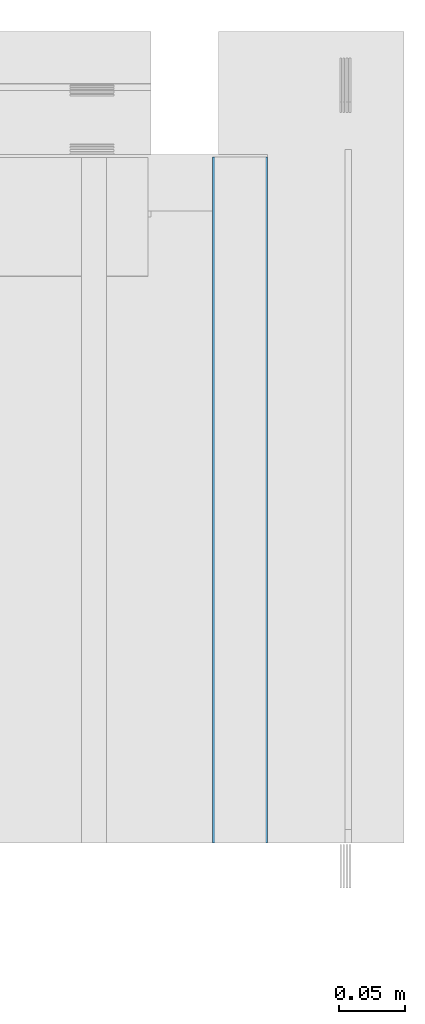
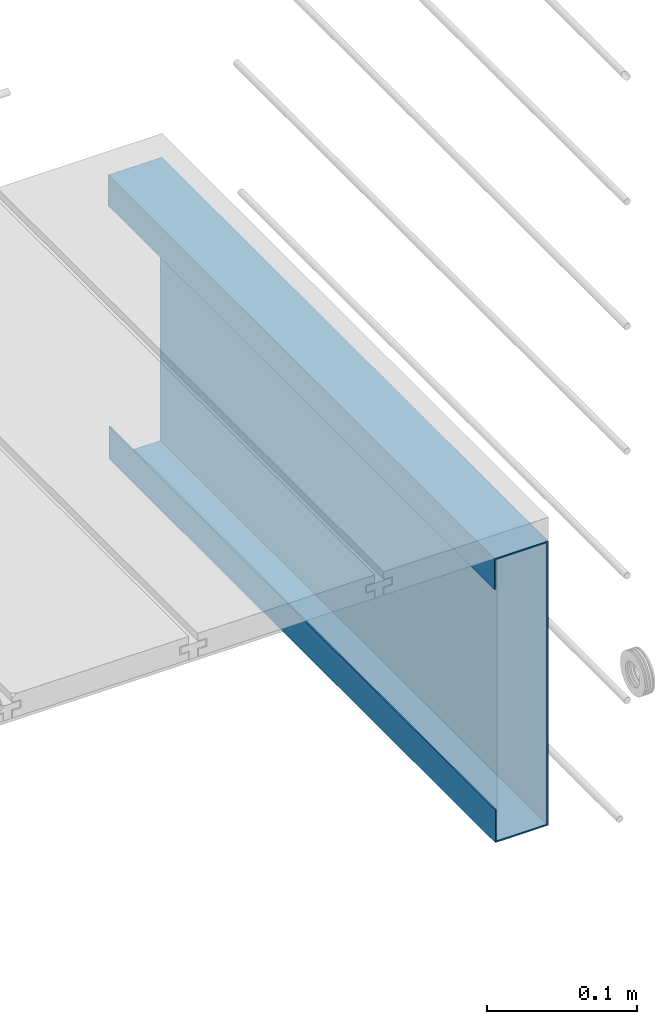
# One storey, part 25 of 33: 1 wall.
"""IFC4 building model written with IfcOpenShell, lengths in feet."""

from ifc_helpers import new_model, entity, si_unit, converted_unit, derived_unit, direction, frame, origin, place, context, subcontext, project, spatial, material, type_object, element, save


model = new_model("IFC4")

# Units and contexts
model_context = context("Model", 3, precision=0.0001, world=origin(), true_north=direction((6.12303176911189e-17, 1.0)))
body_context = subcontext(model_context, "Body", "Model", "MODEL_VIEW")
ifc_project = project(units=[converted_unit("LENGTHUNIT", "FOOT", entity("IfcRatioMeasure", 0.3048), si_unit("LENGTHUNIT", "METRE"), dimensions=[1, 0, 0, 0, 0, 0, 0]), converted_unit("AREAUNIT", "SQUARE FOOT", entity("IfcRatioMeasure", 0.09290304), si_unit("AREAUNIT", "SQUARE_METRE"), dimensions=[2, 0, 0, 0, 0, 0, 0]), converted_unit("VOLUMEUNIT", "CUBIC FOOT", entity("IfcRatioMeasure", 0.028316846592), si_unit("VOLUMEUNIT", "CUBIC_METRE"), dimensions=[3, 0, 0, 0, 0, 0, 0]), converted_unit("PLANEANGLEUNIT", "DEGREE", entity("IfcRatioMeasure", 0.0174532925199433), si_unit("PLANEANGLEUNIT", "RADIAN"), dimensions=[0, 0, 0, 0, 0, 0, 0]), si_unit("MASSUNIT", "GRAM", prefix="KILO"), derived_unit("MASSDENSITYUNIT", [(si_unit("MASSUNIT", "GRAM", prefix="KILO"), 1), (si_unit("LENGTHUNIT", "METRE"), -3)]), derived_unit("MOMENTOFINERTIAUNIT", [(si_unit("LENGTHUNIT", "METRE"), 4)]), si_unit("TIMEUNIT", "SECOND"), si_unit("FREQUENCYUNIT", "HERTZ"), si_unit("THERMODYNAMICTEMPERATUREUNIT", "DEGREE_CELSIUS"), derived_unit("THERMALTRANSMITTANCEUNIT", [(si_unit("MASSUNIT", "GRAM", prefix="KILO"), 1), (si_unit("THERMODYNAMICTEMPERATUREUNIT", "KELVIN"), -1), (si_unit("TIMEUNIT", "SECOND"), -3)]), derived_unit("VOLUMETRICFLOWRATEUNIT", [(si_unit("LENGTHUNIT", "METRE"), 3), (si_unit("TIMEUNIT", "SECOND"), -1)]), si_unit("ELECTRICCURRENTUNIT", "AMPERE"), si_unit("ELECTRICVOLTAGEUNIT", "VOLT"), si_unit("POWERUNIT", "WATT"), si_unit("FORCEUNIT", "NEWTON"), si_unit("ILLUMINANCEUNIT", "LUX"), si_unit("LUMINOUSFLUXUNIT", "LUMEN"), si_unit("LUMINOUSINTENSITYUNIT", "CANDELA"), derived_unit("USERDEFINED", [(si_unit("MASSUNIT", "GRAM", prefix="KILO"), -1), (si_unit("LENGTHUNIT", "METRE"), -2), (si_unit("TIMEUNIT", "SECOND"), 3), (si_unit("LUMINOUSFLUXUNIT", "LUMEN"), 1)]), derived_unit("LINEARVELOCITYUNIT", [(si_unit("LENGTHUNIT", "METRE"), 1), (si_unit("TIMEUNIT", "SECOND"), -1)]), si_unit("PRESSUREUNIT", "PASCAL"), derived_unit("USERDEFINED", [(si_unit("LENGTHUNIT", "METRE"), -2), (si_unit("MASSUNIT", "GRAM", prefix="KILO"), 1), (si_unit("TIMEUNIT", "SECOND"), -2)]), derived_unit("LINEARFORCEUNIT", [(si_unit("MASSUNIT", "GRAM", prefix="KILO"), 1), (si_unit("LENGTHUNIT", "METRE"), 1), (si_unit("TIMEUNIT", "SECOND"), -2), (si_unit("LENGTHUNIT", "METRE"), -1)]), derived_unit("PLANARFORCEUNIT", [(si_unit("MASSUNIT", "GRAM", prefix="KILO"), 1), (si_unit("LENGTHUNIT", "METRE"), 1), (si_unit("TIMEUNIT", "SECOND"), -2), (si_unit("LENGTHUNIT", "METRE"), -2)])], contexts=[model_context])

# Site, building, storey
site_placement = place(None, origin())
site = spatial("IfcSite", under=ifc_project, at=site_placement, CompositionType="ELEMENT")
building_placement = place(site_placement, origin())
building = spatial("IfcBuilding", under=site, at=building_placement, CompositionType="ELEMENT")
storey_placement = place(building_placement, frame((0.0, 0.0, 10.0)))
storey = spatial("IfcBuildingStorey", under=building, at=storey_placement, Name="2ND FLOOR", CompositionType="ELEMENT", Elevation=10.0000000000002)

# Wall
ifc_material = material(Name="METAL FLASHING - BLACK", Category="Materials")
wall_type = type_object("IfcWallType", Name="Generic Models 664:Generic Models 1", PredefinedType="NOTDEFINED", material=ifc_material)
wall_placement = place(storey_placement, frame((1494.16096048663, 3.04611392999272, -0.0780795093916034), z_axis=(0.0, 0.0, 1.0), x_axis=(0.0, 1.0, 0.0)))
cartesian_point_1 = entity("IfcCartesianPoint", [1.69301027184394, -0.13193225761438, 0.00359465998050723])
vertex_point_1 = entity("IfcVertexPoint", cartesian_point_1)
cartesian_point_2 = entity("IfcCartesianPoint", [1.69301027184395, -0.13193225761438, 0.756358646717025])
vertex_point_2 = entity("IfcVertexPoint", cartesian_point_2)
ifc_direction_1 = entity("IfcDirection", [0.0, 0.0, 1.0])
edge_curve_1 = entity("IfcEdgeCurve", vertex_point_1, vertex_point_2, entity("IfcTrimmedCurve", entity("IfcLine", cartesian_point_1, entity("IfcVector", ifc_direction_1, 1.0)), [cartesian_point_1], [cartesian_point_2], True, "CARTESIAN"), True)
cartesian_point_3 = entity("IfcCartesianPoint", [1.69301027184395, -0.0033333333333303, 0.756358646717025])
vertex_point_3 = entity("IfcVertexPoint", cartesian_point_3)
ifc_direction_2 = entity("IfcDirection", [0.0, 1.0, 0.0])
edge_curve_2 = entity("IfcEdgeCurve", vertex_point_2, vertex_point_3, entity("IfcTrimmedCurve", entity("IfcLine", cartesian_point_2, entity("IfcVector", ifc_direction_2, 1.0)), [cartesian_point_2], [cartesian_point_3], True, "CARTESIAN"), True)
cartesian_point_4 = entity("IfcCartesianPoint", [1.69301027184395, -0.0033333333333303, 0.67763552177091])
vertex_point_4 = entity("IfcVertexPoint", cartesian_point_4)
ifc_direction_3 = entity("IfcDirection", [0.0, 0.0, -1.0])
edge_curve_3 = entity("IfcEdgeCurve", vertex_point_3, vertex_point_4, entity("IfcTrimmedCurve", entity("IfcLine", cartesian_point_3, entity("IfcVector", ifc_direction_3, 1.0)), [cartesian_point_3], [cartesian_point_4], True, "CARTESIAN"), True)
cartesian_point_5 = entity("IfcCartesianPoint", [1.69301027184395, 0.0, 0.67763552177091])
vertex_point_5 = entity("IfcVertexPoint", cartesian_point_5)
edge_curve_4 = entity("IfcEdgeCurve", vertex_point_4, vertex_point_5, entity("IfcTrimmedCurve", entity("IfcLine", cartesian_point_4, entity("IfcVector", ifc_direction_2, 1.0)), [cartesian_point_4], [cartesian_point_5], True, "CARTESIAN"), True)
cartesian_point_6 = entity("IfcCartesianPoint", [1.69301027184395, 0.0, 0.759613855050359])
vertex_point_6 = entity("IfcVertexPoint", cartesian_point_6)
edge_curve_5 = entity("IfcEdgeCurve", vertex_point_5, vertex_point_6, entity("IfcTrimmedCurve", entity("IfcLine", cartesian_point_5, entity("IfcVector", ifc_direction_1, 1.0)), [cartesian_point_5], [cartesian_point_6], True, "CARTESIAN"), True)
cartesian_point_7 = entity("IfcCartesianPoint", [1.69301027184395, -0.1358160787629, 0.759613855050359])
vertex_point_7 = entity("IfcVertexPoint", cartesian_point_7)
ifc_direction_4 = entity("IfcDirection", [0.0, -1.0, 0.0])
edge_curve_6 = entity("IfcEdgeCurve", vertex_point_6, vertex_point_7, entity("IfcTrimmedCurve", entity("IfcLine", cartesian_point_6, entity("IfcVector", ifc_direction_4, 1.0)), [cartesian_point_6], [cartesian_point_7], True, "CARTESIAN"), True)
cartesian_point_8 = entity("IfcCartesianPoint", [1.69301027184394, -0.1358160787629, 0.0])
vertex_point_8 = entity("IfcVertexPoint", cartesian_point_8)
edge_curve_7 = entity("IfcEdgeCurve", vertex_point_7, vertex_point_8, entity("IfcTrimmedCurve", entity("IfcLine", cartesian_point_7, entity("IfcVector", ifc_direction_3, 1.0)), [cartesian_point_7], [cartesian_point_8], True, "CARTESIAN"), True)
cartesian_point_9 = entity("IfcCartesianPoint", [1.69301027184394, -0.00195312499954525, 0.0])
vertex_point_9 = entity("IfcVertexPoint", cartesian_point_9)
edge_curve_8 = entity("IfcEdgeCurve", vertex_point_8, vertex_point_9, entity("IfcTrimmedCurve", entity("IfcLine", cartesian_point_8, entity("IfcVector", ifc_direction_2, 1.0)), [cartesian_point_8], [cartesian_point_9], True, "CARTESIAN"), True)
cartesian_point_10 = entity("IfcCartesianPoint", [1.69301027184394, -0.00195312499954525, 0.0868618515013804])
vertex_point_10 = entity("IfcVertexPoint", cartesian_point_10)
edge_curve_9 = entity("IfcEdgeCurve", vertex_point_9, vertex_point_10, entity("IfcTrimmedCurve", entity("IfcLine", cartesian_point_9, entity("IfcVector", ifc_direction_1, 1.0)), [cartesian_point_9], [cartesian_point_10], True, "CARTESIAN"), True)
cartesian_point_11 = entity("IfcCartesianPoint", [1.69301027184394, -0.00528645833287555, 0.0868618515013786])
vertex_point_11 = entity("IfcVertexPoint", cartesian_point_11)
edge_curve_10 = entity("IfcEdgeCurve", vertex_point_10, vertex_point_11, entity("IfcTrimmedCurve", entity("IfcLine", cartesian_point_10, entity("IfcVector", ifc_direction_4, 1.0)), [cartesian_point_10], [cartesian_point_11], True, "CARTESIAN"), True)
cartesian_point_12 = entity("IfcCartesianPoint", [1.69301027184394, -0.00528645833287555, 0.00359465998050723])
vertex_point_12 = entity("IfcVertexPoint", cartesian_point_12)
edge_curve_11 = entity("IfcEdgeCurve", vertex_point_11, vertex_point_12, entity("IfcTrimmedCurve", entity("IfcLine", cartesian_point_11, entity("IfcVector", ifc_direction_3, 1.0)), [cartesian_point_11], [cartesian_point_12], True, "CARTESIAN"), True)
edge_curve_12 = entity("IfcEdgeCurve", vertex_point_12, vertex_point_1, entity("IfcTrimmedCurve", entity("IfcLine", cartesian_point_12, entity("IfcVector", ifc_direction_4, 1.0)), [cartesian_point_12], [cartesian_point_1], True, "CARTESIAN"), True)
ifc_direction_5 = entity("IfcDirection", [1.0, 0.0, 0.0])
cartesian_point_13 = entity("IfcCartesianPoint", [0.0, -0.13193225761438, 0.00359465998051078])
vertex_point_13 = entity("IfcVertexPoint", cartesian_point_13)
cartesian_point_14 = entity("IfcCartesianPoint", [0.0, -0.00528645833287555, 0.00359465998051078])
vertex_point_14 = entity("IfcVertexPoint", cartesian_point_14)
edge_curve_13 = entity("IfcEdgeCurve", vertex_point_13, vertex_point_14, entity("IfcTrimmedCurve", entity("IfcLine", cartesian_point_13, entity("IfcVector", ifc_direction_2, 1.0)), [cartesian_point_13], [cartesian_point_14], True, "CARTESIAN"), True)
cartesian_point_15 = entity("IfcCartesianPoint", [0.0, -0.00528645833287555, 0.0868618515013821])
vertex_point_15 = entity("IfcVertexPoint", cartesian_point_15)
edge_curve_14 = entity("IfcEdgeCurve", vertex_point_14, vertex_point_15, entity("IfcTrimmedCurve", entity("IfcLine", cartesian_point_14, entity("IfcVector", ifc_direction_1, 1.0)), [cartesian_point_14], [cartesian_point_15], True, "CARTESIAN"), True)
cartesian_point_16 = entity("IfcCartesianPoint", [0.0, -0.00195312499954525, 0.0868618515013821])
vertex_point_16 = entity("IfcVertexPoint", cartesian_point_16)
edge_curve_15 = entity("IfcEdgeCurve", vertex_point_15, vertex_point_16, entity("IfcTrimmedCurve", entity("IfcLine", cartesian_point_15, entity("IfcVector", ifc_direction_2, 1.0)), [cartesian_point_15], [cartesian_point_16], True, "CARTESIAN"), True)
cartesian_point_17 = entity("IfcCartesianPoint", [0.0, -0.00195312499954525, 0.0])
vertex_point_17 = entity("IfcVertexPoint", cartesian_point_17)
edge_curve_16 = entity("IfcEdgeCurve", vertex_point_16, vertex_point_17, entity("IfcTrimmedCurve", entity("IfcLine", cartesian_point_16, entity("IfcVector", ifc_direction_3, 1.0)), [cartesian_point_16], [cartesian_point_17], True, "CARTESIAN"), True)
cartesian_point_18 = entity("IfcCartesianPoint", [0.0, -0.1358160787629, 0.0])
vertex_point_18 = entity("IfcVertexPoint", cartesian_point_18)
edge_curve_17 = entity("IfcEdgeCurve", vertex_point_17, vertex_point_18, entity("IfcTrimmedCurve", entity("IfcLine", cartesian_point_17, entity("IfcVector", ifc_direction_4, 1.0)), [cartesian_point_17], [cartesian_point_18], True, "CARTESIAN"), True)
cartesian_point_19 = entity("IfcCartesianPoint", [0.0, -0.1358160787629, 0.759613855050363])
vertex_point_19 = entity("IfcVertexPoint", cartesian_point_19)
edge_curve_18 = entity("IfcEdgeCurve", vertex_point_18, vertex_point_19, entity("IfcTrimmedCurve", entity("IfcLine", cartesian_point_18, entity("IfcVector", ifc_direction_1, 1.0)), [cartesian_point_18], [cartesian_point_19], True, "CARTESIAN"), True)
cartesian_point_20 = entity("IfcCartesianPoint", [0.0, 0.0, 0.759613855050363])
vertex_point_20 = entity("IfcVertexPoint", cartesian_point_20)
edge_curve_19 = entity("IfcEdgeCurve", vertex_point_19, vertex_point_20, entity("IfcTrimmedCurve", entity("IfcLine", cartesian_point_19, entity("IfcVector", ifc_direction_2, 1.0)), [cartesian_point_19], [cartesian_point_20], True, "CARTESIAN"), True)
cartesian_point_21 = entity("IfcCartesianPoint", [0.0, 0.0, 0.677635521770913])
vertex_point_21 = entity("IfcVertexPoint", cartesian_point_21)
edge_curve_20 = entity("IfcEdgeCurve", vertex_point_20, vertex_point_21, entity("IfcTrimmedCurve", entity("IfcLine", cartesian_point_20, entity("IfcVector", ifc_direction_3, 1.0)), [cartesian_point_20], [cartesian_point_21], True, "CARTESIAN"), True)
cartesian_point_22 = entity("IfcCartesianPoint", [0.0, -0.0033333333333303, 0.677635521770913])
vertex_point_22 = entity("IfcVertexPoint", cartesian_point_22)
edge_curve_21 = entity("IfcEdgeCurve", vertex_point_21, vertex_point_22, entity("IfcTrimmedCurve", entity("IfcLine", cartesian_point_21, entity("IfcVector", ifc_direction_4, 1.0)), [cartesian_point_21], [cartesian_point_22], True, "CARTESIAN"), True)
cartesian_point_23 = entity("IfcCartesianPoint", [0.0, -0.0033333333333303, 0.756358646717029])
vertex_point_23 = entity("IfcVertexPoint", cartesian_point_23)
edge_curve_22 = entity("IfcEdgeCurve", vertex_point_22, vertex_point_23, entity("IfcTrimmedCurve", entity("IfcLine", cartesian_point_22, entity("IfcVector", ifc_direction_1, 1.0)), [cartesian_point_22], [cartesian_point_23], True, "CARTESIAN"), True)
cartesian_point_24 = entity("IfcCartesianPoint", [0.0, -0.13193225761438, 0.756358646717029])
vertex_point_24 = entity("IfcVertexPoint", cartesian_point_24)
edge_curve_23 = entity("IfcEdgeCurve", vertex_point_23, vertex_point_24, entity("IfcTrimmedCurve", entity("IfcLine", cartesian_point_23, entity("IfcVector", ifc_direction_4, 1.0)), [cartesian_point_23], [cartesian_point_24], True, "CARTESIAN"), True)
edge_curve_24 = entity("IfcEdgeCurve", vertex_point_24, vertex_point_13, entity("IfcTrimmedCurve", entity("IfcLine", cartesian_point_24, entity("IfcVector", ifc_direction_3, 1.0)), [cartesian_point_24], [cartesian_point_13], True, "CARTESIAN"), True)
ifc_direction_6 = entity("IfcDirection", [-1.0, 0.0, 0.0])
edge_curve_25 = entity("IfcEdgeCurve", vertex_point_18, vertex_point_8, entity("IfcTrimmedCurve", entity("IfcLine", cartesian_point_18, entity("IfcVector", ifc_direction_5, 1.0)), [cartesian_point_18], [cartesian_point_8], True, "CARTESIAN"), True)
edge_curve_26 = entity("IfcEdgeCurve", vertex_point_7, vertex_point_19, entity("IfcTrimmedCurve", entity("IfcLine", cartesian_point_19, entity("IfcVector", ifc_direction_6, 1.0)), [cartesian_point_7], [cartesian_point_19], True, "CARTESIAN"), True)
edge_curve_27 = entity("IfcEdgeCurve", vertex_point_24, vertex_point_2, entity("IfcTrimmedCurve", entity("IfcLine", cartesian_point_24, entity("IfcVector", ifc_direction_5, 1.0)), [cartesian_point_24], [cartesian_point_2], True, "CARTESIAN"), True)
edge_curve_28 = entity("IfcEdgeCurve", vertex_point_1, vertex_point_13, entity("IfcTrimmedCurve", entity("IfcLine", cartesian_point_13, entity("IfcVector", ifc_direction_6, 1.0)), [cartesian_point_1], [cartesian_point_13], True, "CARTESIAN"), True)
edge_curve_29 = entity("IfcEdgeCurve", vertex_point_6, vertex_point_20, entity("IfcTrimmedCurve", entity("IfcLine", cartesian_point_20, entity("IfcVector", ifc_direction_6, 1.0)), [cartesian_point_6], [cartesian_point_20], True, "CARTESIAN"), True)
edge_curve_30 = entity("IfcEdgeCurve", vertex_point_5, vertex_point_21, entity("IfcTrimmedCurve", entity("IfcLine", cartesian_point_21, entity("IfcVector", ifc_direction_6, 1.0)), [cartesian_point_5], [cartesian_point_21], True, "CARTESIAN"), True)
edge_curve_31 = entity("IfcEdgeCurve", vertex_point_4, vertex_point_22, entity("IfcTrimmedCurve", entity("IfcLine", cartesian_point_22, entity("IfcVector", ifc_direction_6, 1.0)), [cartesian_point_4], [cartesian_point_22], True, "CARTESIAN"), True)
edge_curve_32 = entity("IfcEdgeCurve", vertex_point_3, vertex_point_23, entity("IfcTrimmedCurve", entity("IfcLine", cartesian_point_23, entity("IfcVector", ifc_direction_6, 1.0)), [cartesian_point_3], [cartesian_point_23], True, "CARTESIAN"), True)
edge_curve_33 = entity("IfcEdgeCurve", vertex_point_12, vertex_point_14, entity("IfcTrimmedCurve", entity("IfcLine", cartesian_point_14, entity("IfcVector", ifc_direction_6, 1.0)), [cartesian_point_12], [cartesian_point_14], True, "CARTESIAN"), True)
edge_curve_34 = entity("IfcEdgeCurve", vertex_point_11, vertex_point_15, entity("IfcTrimmedCurve", entity("IfcLine", cartesian_point_15, entity("IfcVector", ifc_direction_6, 1.0)), [cartesian_point_11], [cartesian_point_15], True, "CARTESIAN"), True)
edge_curve_35 = entity("IfcEdgeCurve", vertex_point_10, vertex_point_16, entity("IfcTrimmedCurve", entity("IfcLine", cartesian_point_16, entity("IfcVector", ifc_direction_6, 1.0)), [cartesian_point_10], [cartesian_point_16], True, "CARTESIAN"), True)
edge_curve_36 = entity("IfcEdgeCurve", vertex_point_9, vertex_point_17, entity("IfcTrimmedCurve", entity("IfcLine", cartesian_point_17, entity("IfcVector", ifc_direction_6, 1.0)), [cartesian_point_9], [cartesian_point_17], True, "CARTESIAN"), True)
element("IfcWall", 1, at=wall_placement, inside=storey, type_object=wall_type, material=ifc_material, Name="Generic Models 664:Generic Models 1", ObjectType="Generic Models 664:Generic Models 1", PredefinedType="NOTDEFINED", context=body_context, shape_type="AdvancedBrep", body=[
    entity("IfcAdvancedBrep", entity("IfcClosedShell", [entity("IfcAdvancedFace", [entity("IfcFaceOuterBound", entity("IfcEdgeLoop", [entity("IfcOrientedEdge", None, None, edge_curve_1, True), entity("IfcOrientedEdge", None, None, edge_curve_2, True), entity("IfcOrientedEdge", None, None, edge_curve_3, True), entity("IfcOrientedEdge", None, None, edge_curve_4, True), entity("IfcOrientedEdge", None, None, edge_curve_5, True), entity("IfcOrientedEdge", None, None, edge_curve_6, True), entity("IfcOrientedEdge", None, None, edge_curve_7, True), entity("IfcOrientedEdge", None, None, edge_curve_8, True), entity("IfcOrientedEdge", None, None, edge_curve_9, True), entity("IfcOrientedEdge", None, None, edge_curve_10, True), entity("IfcOrientedEdge", None, None, edge_curve_11, True), entity("IfcOrientedEdge", None, None, edge_curve_12, True)]), True)], entity("IfcPlane", entity("IfcAxis2Placement3D", entity("IfcCartesianPoint", [1.69301027184394, -0.00686313477126532, 0.00359465998050723]), ifc_direction_5, ifc_direction_4)), True), entity("IfcAdvancedFace", [entity("IfcFaceOuterBound", entity("IfcEdgeLoop", [entity("IfcOrientedEdge", None, None, edge_curve_13, True), entity("IfcOrientedEdge", None, None, edge_curve_14, True), entity("IfcOrientedEdge", None, None, edge_curve_15, True), entity("IfcOrientedEdge", None, None, edge_curve_16, True), entity("IfcOrientedEdge", None, None, edge_curve_17, True), entity("IfcOrientedEdge", None, None, edge_curve_18, True), entity("IfcOrientedEdge", None, None, edge_curve_19, True), entity("IfcOrientedEdge", None, None, edge_curve_20, True), entity("IfcOrientedEdge", None, None, edge_curve_21, True), entity("IfcOrientedEdge", None, None, edge_curve_22, True), entity("IfcOrientedEdge", None, None, edge_curve_23, True), entity("IfcOrientedEdge", None, None, edge_curve_24, True)]), True)], entity("IfcPlane", entity("IfcAxis2Placement3D", entity("IfcCartesianPoint", [0.0, -0.00686313477126532, 0.00359465998051078]), ifc_direction_6, ifc_direction_2)), True), entity("IfcAdvancedFace", [entity("IfcFaceOuterBound", entity("IfcEdgeLoop", [entity("IfcOrientedEdge", None, None, edge_curve_18, False), entity("IfcOrientedEdge", None, None, edge_curve_25, True), entity("IfcOrientedEdge", None, None, edge_curve_7, False), entity("IfcOrientedEdge", None, None, edge_curve_26, True)]), True)], entity("IfcPlane", entity("IfcAxis2Placement3D", cartesian_point_18, ifc_direction_4, ifc_direction_5)), True), entity("IfcAdvancedFace", [entity("IfcFaceOuterBound", entity("IfcEdgeLoop", [entity("IfcOrientedEdge", None, None, edge_curve_24, False), entity("IfcOrientedEdge", None, None, edge_curve_27, True), entity("IfcOrientedEdge", None, None, edge_curve_1, False), entity("IfcOrientedEdge", None, None, edge_curve_28, True)]), True)], entity("IfcPlane", entity("IfcAxis2Placement3D", cartesian_point_24, ifc_direction_2, ifc_direction_5)), True), entity("IfcAdvancedFace", [entity("IfcFaceOuterBound", entity("IfcEdgeLoop", [entity("IfcOrientedEdge", None, None, edge_curve_19, False), entity("IfcOrientedEdge", None, None, edge_curve_26, False), entity("IfcOrientedEdge", None, None, edge_curve_6, False), entity("IfcOrientedEdge", None, None, edge_curve_29, True)]), True)], entity("IfcPlane", entity("IfcAxis2Placement3D", cartesian_point_19, ifc_direction_1, ifc_direction_5)), True), entity("IfcAdvancedFace", [entity("IfcFaceOuterBound", entity("IfcEdgeLoop", [entity("IfcOrientedEdge", None, None, edge_curve_20, False), entity("IfcOrientedEdge", None, None, edge_curve_29, False), entity("IfcOrientedEdge", None, None, edge_curve_5, False), entity("IfcOrientedEdge", None, None, edge_curve_30, True)]), True)], entity("IfcPlane", entity("IfcAxis2Placement3D", cartesian_point_20, ifc_direction_2, ifc_direction_5)), True), entity("IfcAdvancedFace", [entity("IfcFaceOuterBound", entity("IfcEdgeLoop", [entity("IfcOrientedEdge", None, None, edge_curve_21, False), entity("IfcOrientedEdge", None, None, edge_curve_30, False), entity("IfcOrientedEdge", None, None, edge_curve_4, False), entity("IfcOrientedEdge", None, None, edge_curve_31, True)]), True)], entity("IfcPlane", entity("IfcAxis2Placement3D", cartesian_point_21, ifc_direction_3, ifc_direction_5)), True), entity("IfcAdvancedFace", [entity("IfcFaceOuterBound", entity("IfcEdgeLoop", [entity("IfcOrientedEdge", None, None, edge_curve_22, False), entity("IfcOrientedEdge", None, None, edge_curve_31, False), entity("IfcOrientedEdge", None, None, edge_curve_3, False), entity("IfcOrientedEdge", None, None, edge_curve_32, True)]), True)], entity("IfcPlane", entity("IfcAxis2Placement3D", cartesian_point_22, ifc_direction_4, ifc_direction_5)), True), entity("IfcAdvancedFace", [entity("IfcFaceOuterBound", entity("IfcEdgeLoop", [entity("IfcOrientedEdge", None, None, edge_curve_23, False), entity("IfcOrientedEdge", None, None, edge_curve_32, False), entity("IfcOrientedEdge", None, None, edge_curve_2, False), entity("IfcOrientedEdge", None, None, edge_curve_27, False)]), True)], entity("IfcPlane", entity("IfcAxis2Placement3D", cartesian_point_23, ifc_direction_3, ifc_direction_5)), True), entity("IfcAdvancedFace", [entity("IfcFaceOuterBound", entity("IfcEdgeLoop", [entity("IfcOrientedEdge", None, None, edge_curve_13, False), entity("IfcOrientedEdge", None, None, edge_curve_28, False), entity("IfcOrientedEdge", None, None, edge_curve_12, False), entity("IfcOrientedEdge", None, None, edge_curve_33, True)]), True)], entity("IfcPlane", entity("IfcAxis2Placement3D", cartesian_point_13, ifc_direction_1, ifc_direction_5)), True), entity("IfcAdvancedFace", [entity("IfcFaceOuterBound", entity("IfcEdgeLoop", [entity("IfcOrientedEdge", None, None, edge_curve_14, False), entity("IfcOrientedEdge", None, None, edge_curve_33, False), entity("IfcOrientedEdge", None, None, edge_curve_11, False), entity("IfcOrientedEdge", None, None, edge_curve_34, True)]), True)], entity("IfcPlane", entity("IfcAxis2Placement3D", cartesian_point_14, ifc_direction_4, ifc_direction_5)), True), entity("IfcAdvancedFace", [entity("IfcFaceOuterBound", entity("IfcEdgeLoop", [entity("IfcOrientedEdge", None, None, edge_curve_15, False), entity("IfcOrientedEdge", None, None, edge_curve_34, False), entity("IfcOrientedEdge", None, None, edge_curve_10, False), entity("IfcOrientedEdge", None, None, edge_curve_35, True)]), True)], entity("IfcPlane", entity("IfcAxis2Placement3D", cartesian_point_15, ifc_direction_1, ifc_direction_5)), True), entity("IfcAdvancedFace", [entity("IfcFaceOuterBound", entity("IfcEdgeLoop", [entity("IfcOrientedEdge", None, None, edge_curve_16, False), entity("IfcOrientedEdge", None, None, edge_curve_35, False), entity("IfcOrientedEdge", None, None, edge_curve_9, False), entity("IfcOrientedEdge", None, None, edge_curve_36, True)]), True)], entity("IfcPlane", entity("IfcAxis2Placement3D", cartesian_point_16, ifc_direction_2, ifc_direction_5)), True), entity("IfcAdvancedFace", [entity("IfcFaceOuterBound", entity("IfcEdgeLoop", [entity("IfcOrientedEdge", None, None, edge_curve_17, False), entity("IfcOrientedEdge", None, None, edge_curve_36, False), entity("IfcOrientedEdge", None, None, edge_curve_8, False), entity("IfcOrientedEdge", None, None, edge_curve_25, False)]), True)], entity("IfcPlane", entity("IfcAxis2Placement3D", cartesian_point_17, ifc_direction_3, ifc_direction_5)), True)])),
])

save(model, "model.ifc")
